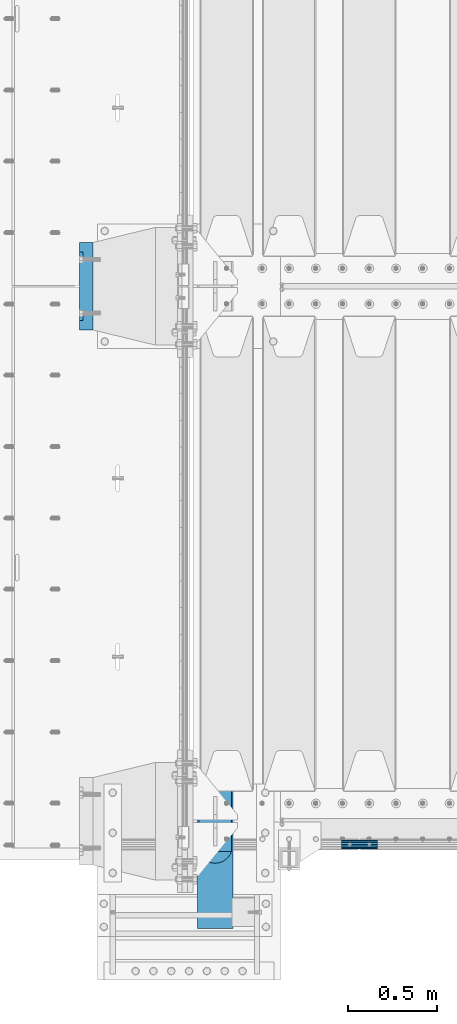
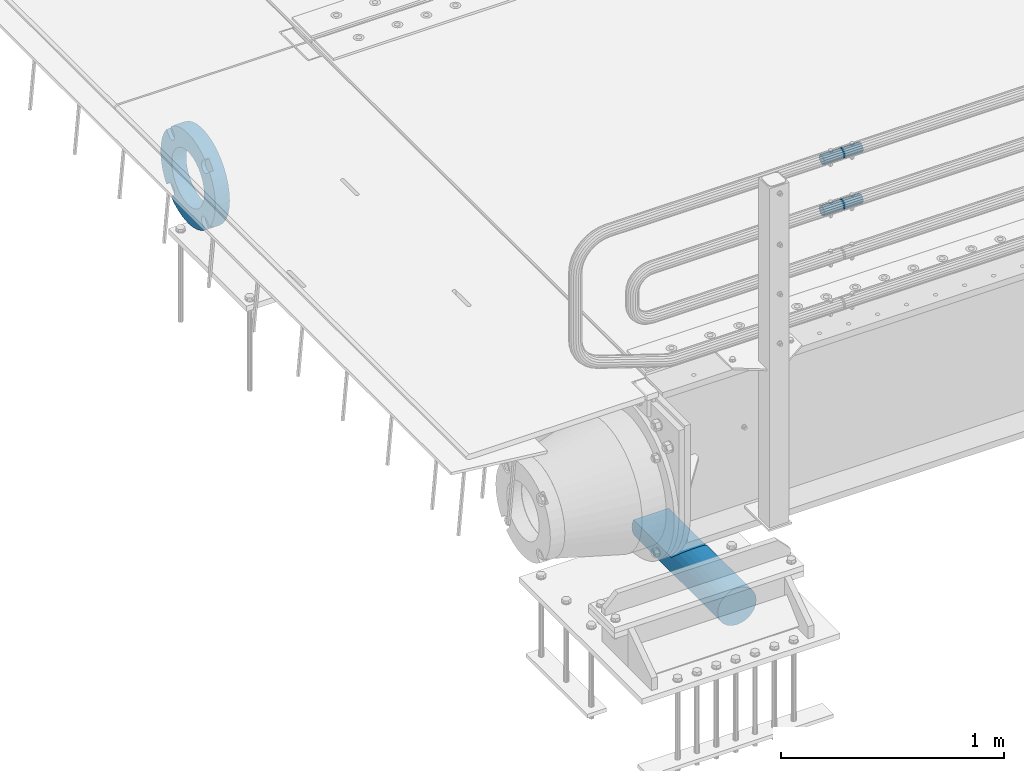
# One storey, part 152 of 270: 4 beams.
"""IFC2X3 building model written with IfcOpenShell, lengths in millimetres."""

from ifc_helpers import new_model, si_unit, frame, origin_with_axes, place, context, subcontext, project, spatial, faceted_brep, material, type_object, element, save


model = new_model("IFC2X3")

# Units and contexts
model_context = context("Model", 3, precision=1e-05, world=origin_with_axes())
body_context = subcontext(model_context, "Body", "Model", "MODEL_VIEW")
ifc_project = project(units=[si_unit("LENGTHUNIT", "METRE", prefix="MILLI"), si_unit("AREAUNIT", "SQUARE_METRE"), si_unit("VOLUMEUNIT", "CUBIC_METRE"), si_unit("MASSUNIT", "GRAM", prefix="KILO"), si_unit("TIMEUNIT", "SECOND"), si_unit("PLANEANGLEUNIT", "RADIAN"), si_unit("SOLIDANGLEUNIT", "STERADIAN"), si_unit("THERMODYNAMICTEMPERATUREUNIT", "DEGREE_CELSIUS"), si_unit("LUMINOUSINTENSITYUNIT", "LUMEN")], contexts=[model_context])

# Site, building, storey
site_placement = place(None, origin_with_axes())
site = spatial("IfcSite", under=ifc_project, at=site_placement, CompositionType="ELEMENT")
building_placement = place(site_placement, origin_with_axes())
building = spatial("IfcBuilding", under=site, at=building_placement, Name="Standard", CompositionType="ELEMENT")
storey_placement = place(building_placement, origin_with_axes())
storey = spatial("IfcBuildingStorey", under=building, at=storey_placement, Name="Undefined", CompositionType="ELEMENT", Elevation=0.0)

# Beams
ifc_material_1 = material(Name="STEEL/S355N")
beam_type_1 = type_object("IfcBeamType", Name="D200", PredefinedType="NOTDEFINED")
beam_1_placement = place(storey_placement, frame((135.0, -24600.0, -938.0), z_axis=(0.0, 0.0, 1.0), x_axis=(0.0, 1.0, 0.0)))
element("IfcBeam", 1, at=beam_1_placement, inside=storey, type_object=beam_type_1, material=ifc_material_1, ObjectType="D200", context=body_context, shape_type="Brep", body=[
    faceted_brep([(417.294117647056, 86.6025403784438, 50.0), (395.365164344954, 70.7106781186548, 70.7106781186548), (378.538486658117, 50.0, 86.6025403784439), (367.960794863509, 25.8819045102521, 96.5925826289068), (364.352941176468, 0.0, 100.0), (367.960794863509, -25.8819045102521, 96.5925826289068), (378.538486658117, -50.0, 86.6025403784439), (395.365164344954, -70.7106781186548, 70.7106781186548), (417.294117647056, -86.6025403784439, 50.0), (430.0, -91.573103126921, 38.0), (430.0, 91.573103126921, 38.0), (770.0, -91.573103126921, 38.0), (770.0, 91.573103126921, 38.0), (0.0, -96.5925826289068, 25.8819045102521), (0.0, -86.6025403784439, 50.0), (0.0, -70.7106781186548, 70.7106781186548), (0.0, -50.0, 86.6025403784439), (0.0, -25.8819045102521, 96.5925826289068), (0.0, 0.0, 100.0), (0.0, 25.8819045102521, 96.5925826289068), (0.0, 50.0, 86.6025403784439), (0.0, 70.7106781186548, 70.7106781186548), (0.0, 86.6025403784438, 50.0), (0.0, 96.5925826289068, 25.8819045102521), (0.0, 100.0, 0.0), (0.0, 96.5925826289068, -25.8819045102521), (0.0, 86.6025403784439, -50.0), (0.0, 70.7106781186548, -70.7106781186548), (0.0, 50.0, -86.6025403784438), (0.0, 25.8819045102522, -96.5925826289067), (0.0, 2.8421709430404e-14, -100.0), (0.0, -25.881904510252, -96.5925826289069), (0.0, -49.9999999999999, -86.6025403784438), (0.0, -70.7106781186548, -70.7106781186548), (0.0, -86.6025403784438, -50.0), (0.0, -96.5925826289068, -25.8819045102522), (0.0, -100.0, 0.0), (770.0, 96.5925826289068, 25.8819045102521), (770.0, 100.0, 0.0), (770.0, 96.5925826289068, -25.8819045102521), (770.0, 86.6025403784439, -50.0), (770.0, 70.7106781186548, -70.7106781186548), (770.0, 50.0000000000001, -86.6025403784438), (770.0, 25.8819045102522, -96.5925826289067), (770.0, 2.8421709430404e-14, -100.0), (770.0, -25.881904510252, -96.5925826289069), (770.0, -49.9999999999999, -86.6025403784438), (770.0, -70.7106781186547, -70.7106781186548), (770.0, -86.6025403784438, -50.0), (770.0, -96.5925826289068, -25.8819045102522), (770.0, -100.0, 0.0), (770.0, -96.5925826289068, 25.8819045102521)], [[[0, 1, 2, 3, 4, 5, 6, 7, 8, 9, 10]], [[10, 9, 11, 12]], [[13, 14, 15, 16, 17, 18, 19, 20, 21, 22, 23, 24, 25, 26, 27, 28, 29, 30, 31, 32, 33, 34, 35, 36]], [[24, 23, 37, 38]], [[25, 24, 38, 39]], [[26, 25, 39, 40]], [[27, 26, 40, 41]], [[28, 27, 41, 42]], [[29, 28, 42, 43]], [[30, 29, 43, 44]], [[31, 30, 44, 45]], [[32, 31, 45, 46]], [[33, 32, 46, 47]], [[34, 33, 47, 48]], [[35, 34, 48, 49]], [[36, 35, 49, 50]], [[13, 36, 50, 51]], [[14, 13, 51, 11, 9, 8]], [[15, 14, 8, 7]], [[16, 15, 7, 6]], [[17, 16, 6, 5]], [[18, 17, 5, 4]], [[19, 18, 4, 3]], [[20, 19, 3, 2]], [[21, 20, 2, 1]], [[22, 21, 1, 0]], [[37, 23, 22, 0, 10, 12]], [[51, 50, 49, 48, 47, 46, 45, 44, 43, 42, 41, 40, 39, 38, 37, 12, 11]]]),
])
ifc_material_2 = material()
beam_type_2 = type_object("IfcBeamType", PredefinedType="NOTDEFINED")
beam_2_placement = place(storey_placement, frame((844.997502999948, -24129.8499999996, 969.849999999726), z_axis=(0.0, 0.0, 1.0), x_axis=(1.0, 0.0, 0.0)))
element("IfcBeam", 2, at=beam_2_placement, inside=storey, type_object=beam_type_2, material=ifc_material_2, context=body_context, shape_type="Brep", body=[
    faceted_brep([(0.0, -21.8999999999996, 0.0), (0.0, -20.232961761998, 8.38076716879547), (200.0, -20.232961761998, 8.38076716879547), (200.0, -21.8999999999996, 0.0), (0.0, -15.4856385079856, 15.4856385079854), (200.0, -15.4856385079856, 15.4856385079854), (0.0, -8.3807671687955, 20.2329617619972), (200.0, -8.3807671687955, 20.2329617619972), (0.0, 0.0, 21.9), (200.0, 0.0, 21.9), (0.0, 8.3807671687955, 20.2329617619972), (200.0, 8.3807671687955, 20.2329617619972), (0.0, 15.4856385079856, 15.4856385079854), (200.0, 15.4856385079856, 15.4856385079854), (0.0, 20.232961761998, 8.38076716879547), (200.0, 20.232961761998, 8.38076716879547), (0.0, 21.8999999999996, 0.0), (200.0, 21.8999999999996, 0.0), (0.0, 20.232961761998, -8.38076716879547), (200.0, 20.232961761998, -8.38076716879547), (0.0, 15.4856385079856, -15.4856385079854), (200.0, 15.4856385079856, -15.4856385079854), (0.0, 8.3807671687955, -20.2329617619972), (200.0, 8.3807671687955, -20.2329617619972), (0.0, 0.0, -21.9), (200.0, 0.0, -21.9), (0.0, -8.3807671687955, -20.2329617619972), (200.0, -8.3807671687955, -20.2329617619972), (0.0, -15.4856385079856, -15.4856385079854), (200.0, -15.4856385079856, -15.4856385079854), (0.0, -20.232961761998, -8.38076716879547), (200.0, -20.232961761998, -8.38076716879547), (0.0, -25.5, 0.0), (0.0, -23.5589280790373, -9.7584275253098), (200.0, -23.5589280790373, -9.7584275253098), (200.0, -25.5, 0.0), (0.0, -18.0312229202573, -18.031222920257), (200.0, -18.0312229202573, -18.031222920257), (0.0, -9.75842752531025, -23.5589280790378), (200.0, -9.75842752531025, -23.5589280790378), (0.0, 0.0, -25.5), (200.0, 0.0, -25.5), (0.0, 9.75842752531025, -23.5589280790378), (200.0, 9.75842752531025, -23.5589280790378), (0.0, 18.0312229202573, -18.031222920257), (200.0, 18.0312229202573, -18.031222920257), (0.0, 23.5589280790373, -9.7584275253098), (200.0, 23.5589280790373, -9.7584275253098), (0.0, 25.5, 0.0), (200.0, 25.5, 0.0), (0.0, 23.5589280790373, 9.7584275253098), (200.0, 23.5589280790373, 9.7584275253098), (0.0, 18.0312229202573, 18.031222920257), (200.0, 18.0312229202573, 18.031222920257), (0.0, 9.75842752531025, 23.5589280790378), (200.0, 9.75842752531025, 23.5589280790378), (0.0, 0.0, 25.5), (200.0, 0.0, 25.5), (0.0, -9.75842752531025, 23.5589280790378), (200.0, -9.75842752531025, 23.5589280790378), (0.0, -18.0312229202573, 18.031222920257), (200.0, -18.0312229202573, 18.031222920257), (0.0, -23.5589280790373, 9.7584275253098), (200.0, -23.5589280790373, 9.7584275253098)], [[[0, 1, 2, 3]], [[1, 4, 5, 2]], [[4, 6, 7, 5]], [[6, 8, 9, 7]], [[8, 10, 11, 9]], [[10, 12, 13, 11]], [[12, 14, 15, 13]], [[14, 16, 17, 15]], [[16, 18, 19, 17]], [[18, 20, 21, 19]], [[20, 22, 23, 21]], [[22, 24, 25, 23]], [[24, 26, 27, 25]], [[26, 28, 29, 27]], [[28, 30, 31, 29]], [[30, 0, 3, 31]], [[32, 33, 34, 35]], [[33, 36, 37, 34]], [[36, 38, 39, 37]], [[38, 40, 41, 39]], [[40, 42, 43, 41]], [[42, 44, 45, 43]], [[44, 46, 47, 45]], [[46, 48, 49, 47]], [[48, 50, 51, 49]], [[50, 52, 53, 51]], [[52, 54, 55, 53]], [[54, 56, 57, 55]], [[56, 58, 59, 57]], [[58, 60, 61, 59]], [[60, 62, 63, 61]], [[62, 32, 35, 63]], [[37, 39, 41, 43, 45, 47, 49, 51, 53, 55, 57, 59, 61, 63, 35, 34], [5, 7, 9, 11, 13, 15, 17, 19, 21, 23, 25, 27, 29, 31, 3, 2]], [[62, 60, 58, 56, 54, 52, 50, 48, 46, 44, 42, 40, 38, 36, 33, 32], [30, 28, 26, 24, 22, 20, 18, 16, 14, 12, 10, 8, 6, 4, 1, 0]]]),
])
beam_3_placement = place(storey_placement, frame((844.997502999948, -24129.8499999996, 689.849999999726), z_axis=(0.0, 0.0, 1.0), x_axis=(1.0, 0.0, 0.0)))
element("IfcBeam", 3, at=beam_3_placement, inside=storey, type_object=beam_type_2, material=ifc_material_2, context=body_context, shape_type="Brep", body=[
    faceted_brep([(0.0, -21.8999999999996, 0.0), (0.0, -20.232961761998, 8.38076716879547), (200.0, -20.232961761998, 8.38076716879547), (200.0, -21.8999999999996, 0.0), (0.0, -15.4856385079856, 15.4856385079854), (200.0, -15.4856385079856, 15.4856385079854), (0.0, -8.3807671687955, 20.2329617619972), (200.0, -8.3807671687955, 20.2329617619972), (0.0, 0.0, 21.9), (200.0, 0.0, 21.9), (0.0, 8.3807671687955, 20.2329617619972), (200.0, 8.3807671687955, 20.2329617619972), (0.0, 15.4856385079856, 15.4856385079854), (200.0, 15.4856385079856, 15.4856385079854), (0.0, 20.232961761998, 8.38076716879547), (200.0, 20.232961761998, 8.38076716879547), (0.0, 21.8999999999996, 0.0), (200.0, 21.8999999999996, 0.0), (0.0, 20.232961761998, -8.38076716879547), (200.0, 20.232961761998, -8.38076716879547), (0.0, 15.4856385079856, -15.4856385079854), (200.0, 15.4856385079856, -15.4856385079854), (0.0, 8.3807671687955, -20.2329617619972), (200.0, 8.3807671687955, -20.2329617619972), (0.0, 0.0, -21.9), (200.0, 0.0, -21.9), (0.0, -8.3807671687955, -20.2329617619972), (200.0, -8.3807671687955, -20.2329617619972), (0.0, -15.4856385079856, -15.4856385079854), (200.0, -15.4856385079856, -15.4856385079854), (0.0, -20.232961761998, -8.38076716879547), (200.0, -20.232961761998, -8.38076716879547), (0.0, -25.5, 0.0), (0.0, -23.5589280790373, -9.7584275253098), (200.0, -23.5589280790373, -9.7584275253098), (200.0, -25.5, 0.0), (0.0, -18.0312229202573, -18.031222920257), (200.0, -18.0312229202573, -18.031222920257), (0.0, -9.75842752531025, -23.5589280790378), (200.0, -9.75842752531025, -23.5589280790378), (0.0, 0.0, -25.5), (200.0, 0.0, -25.5), (0.0, 9.75842752531025, -23.5589280790378), (200.0, 9.75842752531025, -23.5589280790378), (0.0, 18.0312229202573, -18.031222920257), (200.0, 18.0312229202573, -18.031222920257), (0.0, 23.5589280790373, -9.7584275253098), (200.0, 23.5589280790373, -9.7584275253098), (0.0, 25.5, 0.0), (200.0, 25.5, 0.0), (0.0, 23.5589280790373, 9.7584275253098), (200.0, 23.5589280790373, 9.7584275253098), (0.0, 18.0312229202573, 18.031222920257), (200.0, 18.0312229202573, 18.031222920257), (0.0, 9.75842752531025, 23.5589280790378), (200.0, 9.75842752531025, 23.5589280790378), (0.0, 0.0, 25.5), (200.0, 0.0, 25.5), (0.0, -9.75842752531025, 23.5589280790378), (200.0, -9.75842752531025, 23.5589280790378), (0.0, -18.0312229202573, 18.031222920257), (200.0, -18.0312229202573, 18.031222920257), (0.0, -23.5589280790373, 9.7584275253098), (200.0, -23.5589280790373, 9.7584275253098)], [[[0, 1, 2, 3]], [[1, 4, 5, 2]], [[4, 6, 7, 5]], [[6, 8, 9, 7]], [[8, 10, 11, 9]], [[10, 12, 13, 11]], [[12, 14, 15, 13]], [[14, 16, 17, 15]], [[16, 18, 19, 17]], [[18, 20, 21, 19]], [[20, 22, 23, 21]], [[22, 24, 25, 23]], [[24, 26, 27, 25]], [[26, 28, 29, 27]], [[28, 30, 31, 29]], [[30, 0, 3, 31]], [[32, 33, 34, 35]], [[33, 36, 37, 34]], [[36, 38, 39, 37]], [[38, 40, 41, 39]], [[40, 42, 43, 41]], [[42, 44, 45, 43]], [[44, 46, 47, 45]], [[46, 48, 49, 47]], [[48, 50, 51, 49]], [[50, 52, 53, 51]], [[52, 54, 55, 53]], [[54, 56, 57, 55]], [[56, 58, 59, 57]], [[58, 60, 61, 59]], [[60, 62, 63, 61]], [[62, 32, 35, 63]], [[37, 39, 41, 43, 45, 47, 49, 51, 53, 55, 57, 59, 61, 63, 35, 34], [5, 7, 9, 11, 13, 15, 17, 19, 21, 23, 25, 27, 29, 31, 3, 2]], [[62, 60, 58, 56, 54, 52, 50, 48, 46, 44, 42, 40, 38, 36, 33, 32], [30, 28, 26, 24, 22, 20, 18, 16, 14, 12, 10, 8, 6, 4, 1, 0]]]),
])
ifc_material_3 = material(Name="SCN-500-E2")
beam_type_3 = type_object("IfcBeamType", PredefinedType="NOTDEFINED")
beam_4_placement = place(storey_placement, frame((-550.0, -20999.9999985338, -515.0), z_axis=(0.0, 0.0, 1.0), x_axis=(-1.0, 0.0, 0.0)))
element("IfcBeam", 4, at=beam_4_placement, inside=storey, type_object=beam_type_3, material=ifc_material_3, context=body_context, shape_type="Brep", body=[
    faceted_brep([(75.0, 192.717024793295, -150.290616455865), (75.0, 171.473395903973, -129.046987566545), (55.0000000000002, 171.473395903973, -129.046987566545), (55.0000000000002, 192.717024793295, -150.290616455866), (75.0, 167.467485558907, -125.685629673472), (55.0000000000002, 167.467485558907, -125.685629673472), (75.0, 162.938740320598, -123.070957391042), (55.0000000000002, 162.938740320598, -123.070957391042), (75.0, 158.024763821453, -121.282416213469), (55.0000000000002, 158.024763821453, -121.282416213469), (75.0, 152.874864750807, -120.374350059389), (55.0000000000002, 152.874864750807, -120.374350059389), (75.0, 147.645520185946, -120.374350059389), (55.0000000000002, 147.645520185946, -120.374350059389), (75.0, 142.4956211153, -121.282416213469), (55.0000000000002, 142.4956211153, -121.282416213469), (75.0, 137.581644616155, -123.070957391042), (55.0000000000002, 137.581644616155, -123.070957391042), (75.0, 133.052899377846, -125.685629673472), (55.0000000000002, 133.052899377846, -125.685629673472), (75.0, 129.04698903278, -129.046987566545), (55.0000000000002, 129.04698903278, -129.046987566545), (75.0, 125.685631139708, -133.05289791161), (55.0000000000002, 125.685631139708, -133.05289791161), (75.0, 123.070958857277, -137.581643149921), (55.0000000000002, 123.070958857277, -137.581643149921), (75.0, 121.282417679704, -142.495619649066), (55.0000000000002, 121.282417679704, -142.495619649066), (75.0, 120.374351525625, -147.645518719712), (55.0000000000002, 120.374351525625, -147.645518719712), (75.0, 120.374351525625, -152.874863284571), (55.0000000000002, 120.374351525625, -152.874863284571), (75.0, 121.282417679706, -158.024762355217), (55.0000000000002, 121.282417679706, -158.024762355217), (75.0, 123.070958857277, -162.938738854362), (55.0000000000002, 123.070958857277, -162.938738854362), (75.0, 125.685631139708, -167.467484092673), (55.0000000000002, 125.685631139708, -167.467484092673), (75.0, 129.04698903278, -171.473394437738), (55.0000000000002, 129.04698903278, -171.473394437738), (55.0000000000002, 150.290618180639, -192.717023585596), (75.0, 150.290618180637, -192.717023585598), (55.0000000000002, 157.482964373203, -187.68088856415), (55.0000000000002, 187.680888564149, -157.482964373202), (75.0, -192.717023585596, 150.290618180639), (75.0000000000001, -171.4733929715, 129.046987566544), (55.0000000000002, -171.4733929715, 129.046987566544), (55.0000000000002, -192.717023585596, 150.290618180638), (75.0000000000001, -167.467482626435, 125.68562967347), (55.0000000000002, -167.467482626435, 125.68562967347), (75.0000000000001, -162.938737388125, 123.070957391041), (55.0000000000002, -162.938737388125, 123.070957391041), (75.0000000000001, -158.02476088898, 121.282416213468), (55.0000000000002, -158.02476088898, 121.282416213468), (75.0000000000001, -152.874861818334, 120.374350059388), (55.0000000000002, -152.874861818334, 120.374350059388), (75.0000000000001, -147.645517253473, 120.374350059388), (55.0000000000002, -147.645517253473, 120.374350059388), (75.0000000000001, -142.495618182829, 121.282416213468), (55.0000000000002, -142.495618182829, 121.282416213468), (75.0000000000001, -137.581641683682, 123.070957391041), (55.0000000000002, -137.581641683682, 123.070957391041), (75.0000000000001, -133.052896445373, 125.685629673471), (55.0000000000002, -133.052896445373, 125.685629673471), (75.0000000000001, -129.046986100308, 129.046987566544), (55.0000000000002, -129.046986100308, 129.046987566544), (75.0000000000001, -125.685628207235, 133.052897911609), (55.0000000000002, -125.685628207235, 133.052897911609), (75.0000000000001, -123.070955924804, 137.581643149919), (55.0000000000002, -123.070955924804, 137.581643149919), (75.0000000000001, -121.282414747231, 142.495619649065), (55.0000000000002, -121.282414747231, 142.495619649065), (75.0000000000001, -120.374348593152, 147.645518719711), (55.0000000000002, -120.374348593152, 147.645518719711), (75.0000000000001, -120.374348593152, 152.87486328457), (55.0000000000002, -120.374348593152, 152.87486328457), (75.0000000000001, -121.282414747231, 158.024762355216), (55.0000000000002, -121.282414747231, 158.024762355216), (75.0000000000001, -123.070955924804, 162.938738854361), (55.0000000000002, -123.070955924804, 162.938738854361), (75.0000000000001, -125.685628207235, 167.467484092672), (55.0000000000002, -125.685628207235, 167.467484092672), (75.0000000000001, -129.046986100308, 171.473394437737), (55.0000000000002, -129.046986100308, 171.473394437737), (55.0000000000002, -150.290616455866, 192.717024793296), (75.0, -150.290616455866, 192.717024793296), (75.0, 150.290618180637, 192.717023585597), (75.0, 129.04698903278, 171.473394437739), (55.0000000000002, 129.04698903278, 171.473394437739), (55.0000000000002, 150.290618180637, 192.717023585597), (75.0, 125.685631139708, 167.467484092674), (55.0000000000002, 125.685631139708, 167.467484092674), (75.0, 123.070958857277, 162.938738854364), (55.0000000000002, 123.070958857277, 162.938738854364), (75.0, 121.282417679704, 158.024762355218), (55.0000000000002, 121.282417679704, 158.024762355218), (75.0, 120.374351525625, 152.874863284573), (55.0000000000002, 120.374351525625, 152.874863284573), (75.0, 120.374351525625, 147.645518719713), (55.0000000000002, 120.374351525625, 147.645518719713), (75.0, 121.282417679704, 142.495619649067), (55.0000000000002, 121.282417679704, 142.495619649067), (75.0, 123.070958857277, 137.581643149922), (55.0000000000002, 123.070958857277, 137.581643149922), (75.0, 125.685631139708, 133.052897911611), (55.0000000000002, 125.685631139708, 133.052897911611), (75.0, 129.04698903278, 129.046987566546), (55.0000000000002, 129.04698903278, 129.046987566546), (75.0, 133.052899377846, 125.685629673473), (55.0000000000002, 133.052899377846, 125.685629673473), (75.0, 137.581644616155, 123.070957391043), (55.0000000000002, 137.581644616155, 123.070957391043), (75.0, 142.4956211153, 121.282416213471), (55.0000000000002, 142.4956211153, 121.282416213471), (75.0, 147.645520185946, 120.37435005939), (55.0000000000002, 147.645520185946, 120.37435005939), (75.0, 152.874864750807, 120.37435005939), (55.0000000000002, 152.874864750807, 120.37435005939), (75.0000000000001, 158.024763821453, 121.282416213471), (55.0000000000002, 158.024763821453, 121.282416213471), (75.0000000000001, 162.938740320598, 123.070957391043), (55.0000000000002, 162.938740320598, 123.070957391043), (75.0000000000001, 167.467485558907, 125.685629673473), (55.0000000000002, 167.467485558907, 125.685629673473), (75.0000000000001, 171.473395903973, 129.046987566546), (55.0000000000002, 171.473395903973, 129.046987566546), (55.0000000000002, 192.717024793294, 150.290616455866), (75.0, 192.717024793295, 150.290616455867), (0.0, 212.176223927188, -122.5), (0.0, 230.224692092548, -83.7949351147888), (75.0, 230.224692092548, -83.7949351147888), (75.0, 212.176223927188, -122.5), (0.0, 241.277899487992, -42.5438035283978), (75.0, 241.277899487992, -42.5438035283978), (0.0, 245.0, 0.0), (75.0, 245.0, 0.0), (0.0, 241.277899487992, 42.543803528398), (75.0, 241.277899487992, 42.543803528398), (0.0, 230.224692092548, 83.7949351147889), (75.0, 230.224692092548, 83.7949351147889), (0.0, 212.176223927188, 122.5), (75.0, 212.176223927188, 122.5), (0.0, 187.680888564149, 157.482964373202), (55.0000000000002, 187.680888564149, 157.482964373202), (0.0, 157.482964373203, 187.68088856415), (55.0000000000002, 157.482964373203, 187.68088856415), (0.0, 122.5, 212.176223927187), (75.0, 122.5, 212.176223927187), (0.0, 83.794935114789, 230.224692092548), (75.0, 83.794935114789, 230.224692092548), (0.0, 42.5438035283987, 241.277899487991), (75.0, 42.5438035283987, 241.277899487991), (0.0, 0.0, 245.0), (75.0, 0.0, 245.0), (0.0, -42.5438035283987, 241.277899487991), (75.0, -42.5438035283987, 241.277899487991), (0.0, -83.794935114789, 230.224692092548), (75.0, -83.794935114789, 230.224692092548), (0.0, -122.5, 212.176223927187), (75.0, -122.5, 212.176223927187), (0.0, -157.482964373203, 187.68088856415), (55.0000000000002, -157.482964373203, 187.68088856415), (0.0, -187.680888564149, 157.482964373202), (55.0000000000002, -187.680888564149, 157.482964373202), (0.0, -212.176223927188, 122.5), (75.0, -212.176223927188, 122.5), (0.0, -230.224692092548, 83.7949351147888), (75.0, -230.224692092548, 83.7949351147888), (0.0, -241.277899487992, 42.5438035283979), (75.0, -241.277899487992, 42.5438035283979), (0.0, -245.0, 0.0), (75.0, -245.0, 0.0), (0.0, -187.680888564149, -157.482964373202), (0.0, -157.482964373203, -187.68088856415), (55.0000000000002, -157.482964373203, -187.68088856415), (55.0000000000002, -187.680888564149, -157.482964373202), (0.0, 83.794935114789, -230.224692092547), (0.0, 122.5, -212.176223927187), (75.0, 122.5, -212.176223927187), (75.0, 83.794935114789, -230.224692092547), (0.0, 42.5438035283987, -241.277899487991), (75.0, 42.5438035283987, -241.277899487991), (0.0, 0.0, -245.0), (75.0, 0.0, -245.0), (0.0, -42.5438035283987, -241.277899487991), (75.0, -42.5438035283987, -241.277899487991), (0.0, -83.794935114789, -230.224692092548), (75.0, -83.794935114789, -230.224692092548), (0.0, -122.5, -212.176223927187), (75.0, -122.5, -212.176223927187), (75.0, -150.290616455866, -192.717024793296), (55.0000000000002, -150.290616455866, -192.717024793297), (55.0000000000002, -129.046986100308, -171.473394437739), (55.0000000000002, -125.685628207235, -167.467484092674), (55.0000000000002, -123.070955924804, -162.938738854364), (55.0000000000002, -121.282414747233, -158.024762355219), (55.0000000000002, -120.374348593152, -152.874863284573), (55.0000000000002, -120.374348593152, -147.645518719713), (55.0000000000002, -121.282414747233, -142.495619649067), (55.0000000000002, -123.070955924804, -137.581643149922), (55.0000000000002, -125.685628207235, -133.052897911612), (55.0000000000002, -129.046986100308, -129.046987566547), (55.0000000000002, -133.052896445373, -125.685629673473), (55.0000000000002, -137.581641683682, -123.070957391043), (55.0000000000002, -142.495618182827, -121.282416213471), (55.0000000000002, -147.645517253473, -120.374350059391), (55.0000000000002, -152.874861818334, -120.374350059391), (55.0000000000002, -158.02476088898, -121.282416213471), (55.0000000000002, -162.938737388125, -123.070957391043), (55.0000000000002, -167.467482626435, -125.685629673473), (55.0000000000002, -171.4733929715, -129.046987566546), (55.0000000000002, -192.717023585594, -150.29061818064), (75.0, -129.046986100308, -171.473394437739), (75.0, -125.685628207235, -167.467484092674), (75.0, -123.070955924804, -162.938738854364), (75.0, -121.282414747233, -158.024762355219), (75.0, -120.374348593152, -152.874863284573), (75.0, -120.374348593152, -147.645518719713), (75.0, -121.282414747233, -142.495619649067), (75.0, -123.070955924804, -137.581643149922), (75.0, -125.685628207235, -133.052897911612), (75.0, -129.046986100308, -129.046987566547), (75.0, -133.052896445373, -125.685629673473), (75.0, -137.581641683682, -123.070957391043), (75.0, -142.495618182827, -121.282416213471), (75.0, -147.645517253473, -120.374350059391), (75.0, -152.874861818334, -120.374350059391), (75.0, -158.02476088898, -121.282416213471), (75.0, -162.938737388125, -123.070957391043), (75.0, -167.467482626435, -125.685629673473), (75.0, -171.4733929715, -129.046987566546), (75.0, -192.717023585594, -150.290618180641), (75.0, -212.176223927187, -122.5), (0.0, -212.176223927187, -122.5), (0.0, -230.224692092548, -83.794935114789), (75.0, -230.224692092548, -83.794935114789), (0.0, -241.277899487992, -42.5438035283979), (75.0, -241.277899487992, -42.5438035283979), (0.0, 187.680888564149, -157.482964373202), (0.0, 157.482964373203, -187.68088856415), (0.0, -142.797124186771, -25.1789857617049), (0.0, -136.255430013956, -49.592920782222), (0.0, -125.573683548744, -72.5), (0.0, -111.076444252252, -93.2042034045483), (0.0, -93.204203404548, -111.076444252252), (0.0, -72.5, -125.573683548744), (0.0, -49.5929207822228, -136.255430013957), (0.0, -25.1789857617041, -142.79712418677), (0.0, 0.0, -145.0), (0.0, 25.1789857617041, -142.79712418677), (0.0, 49.5929207822228, -136.255430013957), (0.0, 72.5, -125.573683548744), (0.0, 93.204203404548, -111.076444252252), (0.0, 111.076444252252, -93.2042034045483), (0.0, 125.573683548744, -72.5), (0.0, 136.255430013956, -49.592920782222), (0.0, 142.797124186771, -25.178985761705), (0.0, 145.0, 0.0), (0.0, 142.797124186771, 25.1789857617048), (0.0, 136.255430013956, 49.5929207822219), (0.0, 125.573683548744, 72.4999999999999), (0.0, 111.076444252252, 93.2042034045482), (0.0, 93.204203404548, 111.076444252252), (0.0, 72.5, 125.573683548744), (0.0, 49.5929207822228, 136.255430013957), (0.0, 25.1789857617041, 142.79712418677), (0.0, 0.0, 145.0), (0.0, -25.1789857617041, 142.79712418677), (0.0, -49.5929207822228, 136.255430013957), (0.0, -72.5, 125.573683548744), (0.0, -93.204203404548, 111.076444252252), (0.0, -111.076444252252, 93.2042034045483), (0.0, -125.573683548744, 72.5000000000001), (0.0, -136.255430013956, 49.5929207822221), (0.0, -142.797124186771, 25.1789857617049), (0.0, -145.0, 0.0), (75.0, -145.0, 0.0), (75.0, -142.797124186771, -25.1789857617049), (75.0, -136.255430013956, -49.592920782222), (75.0, -125.573683548744, -72.5), (75.0, -111.076444252252, -93.2042034045483), (75.0, -93.204203404548, -111.076444252252), (75.0, -72.5, -125.573683548744), (75.0, -49.5929207822228, -136.255430013957), (75.0, -25.1789857617041, -142.79712418677), (75.0, 0.0, -145.0), (75.0, 25.1789857617041, -142.79712418677), (75.0, 49.5929207822228, -136.255430013957), (75.0, 72.5, -125.573683548744), (75.0, 93.204203404548, -111.076444252252), (75.0, 111.076444252252, -93.2042034045483), (75.0, 125.573683548744, -72.5), (75.0, 136.255430013956, -49.592920782222), (75.0, 142.797124186771, -25.178985761705), (75.0, 145.0, 0.0), (75.0, 142.797124186771, 25.1789857617048), (75.0, 136.255430013956, 49.5929207822219), (75.0, 125.573683548744, 72.4999999999999), (75.0, 111.076444252252, 93.2042034045482), (75.0, 93.204203404548, 111.076444252252), (75.0, 72.5, 125.573683548744), (75.0, 49.5929207822228, 136.255430013957), (75.0, 25.1789857617041, 142.79712418677), (75.0, 0.0, 145.0), (75.0, -25.1789857617041, 142.79712418677), (75.0, -49.5929207822228, 136.255430013957), (75.0, -72.5, 125.573683548744), (75.0, -93.204203404548, 111.076444252252), (75.0, -111.076444252252, 93.2042034045483), (75.0, -125.573683548744, 72.5000000000001), (75.0, -136.255430013956, 49.5929207822221), (75.0, -142.797124186771, 25.1789857617049)], [[[0, 1, 2, 3]], [[4, 5, 2, 1]], [[6, 7, 5, 4]], [[8, 9, 7, 6]], [[10, 11, 9, 8]], [[12, 13, 11, 10]], [[14, 15, 13, 12]], [[16, 17, 15, 14]], [[18, 19, 17, 16]], [[20, 21, 19, 18]], [[22, 23, 21, 20]], [[24, 25, 23, 22]], [[26, 27, 25, 24]], [[28, 29, 27, 26]], [[30, 31, 29, 28]], [[32, 33, 31, 30]], [[34, 35, 33, 32]], [[36, 37, 35, 34]], [[38, 39, 37, 36]], [[40, 39, 38, 41]], [[42, 43, 3, 2, 5, 7, 9, 11, 13, 15, 17, 19, 21, 23, 25, 27, 29, 31, 33, 35, 37, 39, 40]], [[44, 45, 46, 47]], [[48, 49, 46, 45]], [[50, 51, 49, 48]], [[52, 53, 51, 50]], [[54, 55, 53, 52]], [[56, 57, 55, 54]], [[58, 59, 57, 56]], [[60, 61, 59, 58]], [[62, 63, 61, 60]], [[64, 65, 63, 62]], [[66, 67, 65, 64]], [[68, 69, 67, 66]], [[70, 71, 69, 68]], [[72, 73, 71, 70]], [[74, 75, 73, 72]], [[76, 77, 75, 74]], [[78, 79, 77, 76]], [[80, 81, 79, 78]], [[82, 83, 81, 80]], [[84, 83, 82, 85]], [[86, 87, 88, 89]], [[90, 91, 88, 87]], [[92, 93, 91, 90]], [[94, 95, 93, 92]], [[96, 97, 95, 94]], [[98, 99, 97, 96]], [[100, 101, 99, 98]], [[102, 103, 101, 100]], [[104, 105, 103, 102]], [[106, 107, 105, 104]], [[108, 109, 107, 106]], [[110, 111, 109, 108]], [[112, 113, 111, 110]], [[114, 115, 113, 112]], [[116, 117, 115, 114]], [[118, 119, 117, 116]], [[120, 121, 119, 118]], [[122, 123, 121, 120]], [[124, 125, 123, 122]], [[126, 125, 124, 127]], [[128, 129, 130, 131]], [[129, 132, 133, 130]], [[132, 134, 135, 133]], [[134, 136, 137, 135]], [[136, 138, 139, 137]], [[138, 140, 141, 139]], [[127, 141, 140, 142, 143, 126]], [[142, 144, 145, 143]], [[89, 88, 91, 93, 95, 97, 99, 101, 103, 105, 107, 109, 111, 113, 115, 117, 119, 121, 123, 125, 126, 143, 145]], [[144, 146, 147, 86, 89, 145]], [[146, 148, 149, 147]], [[148, 150, 151, 149]], [[150, 152, 153, 151]], [[152, 154, 155, 153]], [[154, 156, 157, 155]], [[156, 158, 159, 157]], [[85, 159, 158, 160, 161, 84]], [[160, 162, 163, 161]], [[47, 46, 49, 51, 53, 55, 57, 59, 61, 63, 65, 67, 69, 71, 73, 75, 77, 79, 81, 83, 84, 161, 163]], [[162, 164, 165, 44, 47, 163]], [[164, 166, 167, 165]], [[166, 168, 169, 167]], [[168, 170, 171, 169]], [[172, 173, 174, 175]], [[176, 177, 178, 179]], [[180, 176, 179, 181]], [[182, 180, 181, 183]], [[184, 182, 183, 185]], [[186, 184, 185, 187]], [[188, 186, 187, 189]], [[173, 188, 189, 190, 191, 174]], [[175, 174, 191, 192, 193, 194, 195, 196, 197, 198, 199, 200, 201, 202, 203, 204, 205, 206, 207, 208, 209, 210, 211]], [[190, 212, 192, 191]], [[213, 193, 192, 212]], [[214, 194, 193, 213]], [[215, 195, 194, 214]], [[216, 196, 195, 215]], [[217, 197, 196, 216]], [[218, 198, 197, 217]], [[219, 199, 198, 218]], [[220, 200, 199, 219]], [[221, 201, 200, 220]], [[222, 202, 201, 221]], [[223, 203, 202, 222]], [[224, 204, 203, 223]], [[225, 205, 204, 224]], [[226, 206, 205, 225]], [[227, 207, 206, 226]], [[228, 208, 207, 227]], [[229, 209, 208, 228]], [[230, 210, 209, 229]], [[211, 210, 230, 231]], [[232, 233, 172, 175, 211, 231]], [[234, 233, 232, 235]], [[236, 234, 235, 237]], [[170, 236, 237, 171]], [[168, 166, 164, 162, 160, 158, 156, 154, 152, 150, 148, 146, 144, 142, 140, 138, 136, 134, 132, 129, 128, 238, 239, 177, 176, 180, 182, 184, 186, 188, 173, 172, 233, 234, 236, 170], [240, 241, 242, 243, 244, 245, 246, 247, 248, 249, 250, 251, 252, 253, 254, 255, 256, 257, 258, 259, 260, 261, 262, 263, 264, 265, 266, 267, 268, 269, 270, 271, 272, 273, 274, 275]], [[240, 275, 276, 277]], [[241, 240, 277, 278]], [[242, 241, 278, 279]], [[243, 242, 279, 280]], [[244, 243, 280, 281]], [[245, 244, 281, 282]], [[246, 245, 282, 283]], [[247, 246, 283, 284]], [[248, 247, 284, 285]], [[249, 248, 285, 286]], [[250, 249, 286, 287]], [[251, 250, 287, 288]], [[252, 251, 288, 289]], [[253, 252, 289, 290]], [[254, 253, 290, 291]], [[255, 254, 291, 292]], [[256, 255, 292, 293]], [[257, 256, 293, 294]], [[258, 257, 294, 295]], [[259, 258, 295, 296]], [[260, 259, 296, 297]], [[261, 260, 297, 298]], [[262, 261, 298, 299]], [[263, 262, 299, 300]], [[264, 263, 300, 301]], [[265, 264, 301, 302]], [[266, 265, 302, 303]], [[267, 266, 303, 304]], [[268, 267, 304, 305]], [[269, 268, 305, 306]], [[270, 269, 306, 307]], [[271, 270, 307, 308]], [[272, 271, 308, 309]], [[273, 272, 309, 310]], [[274, 273, 310, 311]], [[275, 274, 311, 276]], [[24, 22, 20, 18, 16, 14, 12, 10, 8, 6, 4, 1, 0, 131, 130, 133, 135, 137, 139, 141, 127, 124, 122, 120, 118, 116, 114, 112, 110, 108, 106, 104, 102, 100, 98, 96, 94, 92, 90, 87, 86, 147, 149, 151, 153, 155, 157, 159, 85, 82, 80, 78, 76, 74, 72, 70, 68, 66, 64, 62, 60, 58, 56, 54, 52, 50, 48, 45, 44, 165, 167, 169, 171, 237, 235, 232, 231, 230, 229, 228, 227, 226, 225, 224, 223, 222, 221, 220, 219, 218, 217, 216, 215, 214, 213, 212, 190, 189, 187, 185, 183, 181, 179, 178, 41, 38, 36, 34, 32, 30, 28, 26], [310, 309, 308, 307, 306, 305, 304, 303, 302, 301, 300, 299, 298, 297, 296, 295, 294, 293, 292, 291, 290, 289, 288, 287, 286, 285, 284, 283, 282, 281, 280, 279, 278, 277, 276, 311]], [[238, 128, 131, 0, 3, 43]], [[239, 238, 43, 42]], [[178, 177, 239, 42, 40, 41]]]),
])

save(model, "model.ifc")
